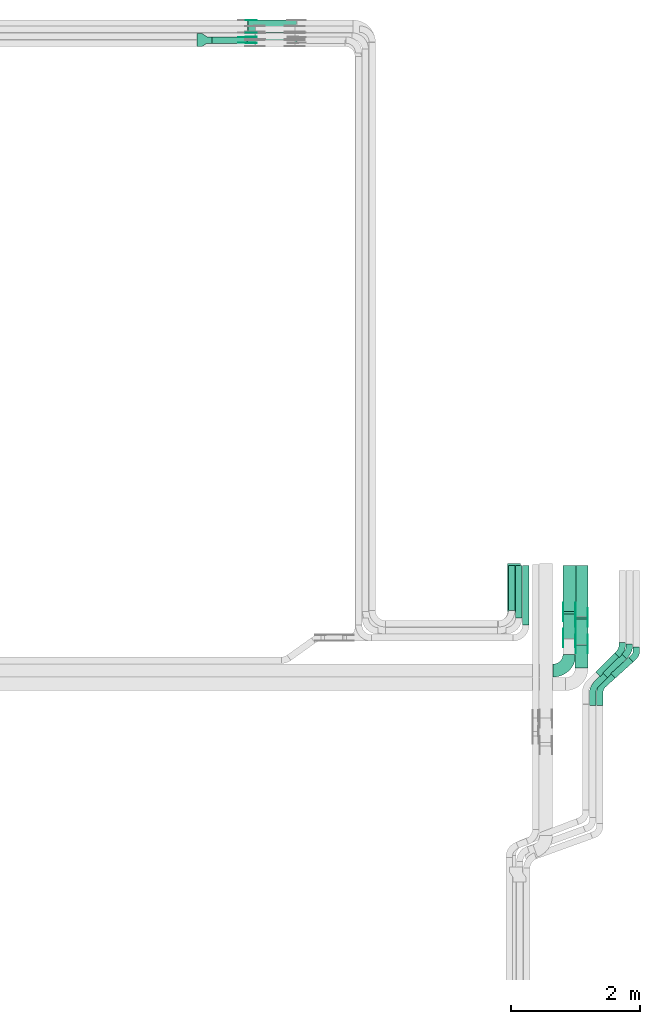
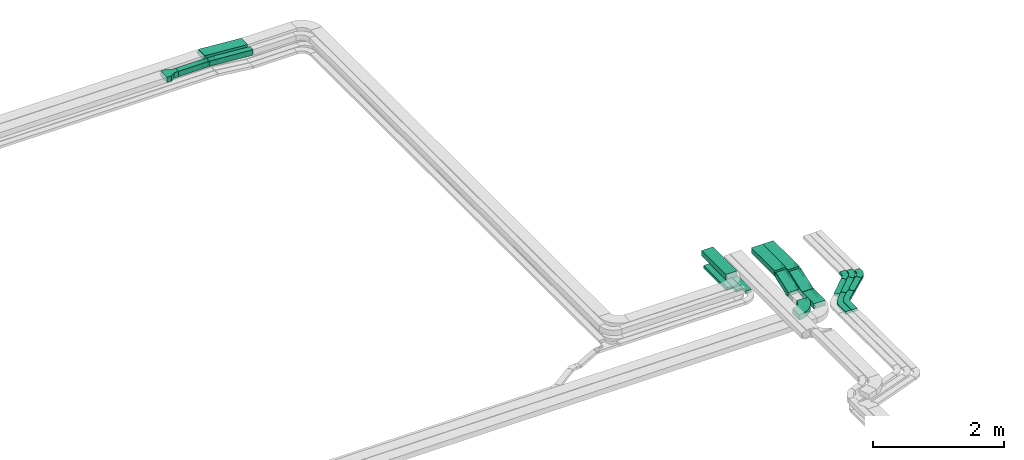
# One storey, part 21 of 23: 29 flow fittings, 15 flow segments.
"""IFC2X3 building model written with IfcOpenShell, lengths in millimetres."""

from ifc_helpers import new_model, entity, si_unit, converted_unit, derived_unit, direction, frame, frame_2d, origin, origin_2d_with_axis, place, context, subcontext, project, spatial, polyline, circle_curve, parameter, trimmed, segment, composite_curve, rectangle, outline, extrude, source, transform, mapped, material, type_object, type_shapes, element, save


model = new_model("IFC2X3")

# Units and contexts
model_context = context("Model", 3, precision=0.01, world=origin(), true_north=direction((6.12303176911189e-17, 1.0)))
body_context = subcontext(model_context, "Body", "Model", "MODEL_VIEW")
ifc_project = project(units=[si_unit("LENGTHUNIT", "METRE", prefix="MILLI"), si_unit("AREAUNIT", "SQUARE_METRE"), si_unit("VOLUMEUNIT", "CUBIC_METRE"), converted_unit("PLANEANGLEUNIT", "DEGREE", entity("IfcRatioMeasure", 0.0174532925199433), si_unit("PLANEANGLEUNIT", "RADIAN"), dimensions=[0, 0, 0, 0, 0, 0, 0]), si_unit("MASSUNIT", "GRAM", prefix="KILO"), derived_unit("MASSDENSITYUNIT", [(si_unit("MASSUNIT", "GRAM", prefix="KILO"), 1), (si_unit("LENGTHUNIT", "METRE"), -3)]), derived_unit("MOMENTOFINERTIAUNIT", [(si_unit("LENGTHUNIT", "METRE"), 4)]), si_unit("TIMEUNIT", "SECOND"), si_unit("FREQUENCYUNIT", "HERTZ"), si_unit("THERMODYNAMICTEMPERATUREUNIT", "DEGREE_CELSIUS"), derived_unit("THERMALTRANSMITTANCEUNIT", [(si_unit("MASSUNIT", "GRAM", prefix="KILO"), 1), (si_unit("THERMODYNAMICTEMPERATUREUNIT", "KELVIN"), -1), (si_unit("TIMEUNIT", "SECOND"), -3)]), derived_unit("VOLUMETRICFLOWRATEUNIT", [(si_unit("LENGTHUNIT", "METRE"), 3), (si_unit("TIMEUNIT", "SECOND"), -1)]), derived_unit("MASSFLOWRATEUNIT", [(si_unit("MASSUNIT", "GRAM", prefix="KILO"), 1), (si_unit("TIMEUNIT", "SECOND"), -1)]), derived_unit("ROTATIONALFREQUENCYUNIT", [(si_unit("TIMEUNIT", "SECOND"), -1)]), si_unit("ELECTRICCURRENTUNIT", "AMPERE"), si_unit("ELECTRICVOLTAGEUNIT", "VOLT"), si_unit("POWERUNIT", "WATT"), si_unit("FORCEUNIT", "NEWTON", prefix="KILO"), si_unit("ILLUMINANCEUNIT", "LUX"), si_unit("LUMINOUSFLUXUNIT", "LUMEN"), si_unit("LUMINOUSINTENSITYUNIT", "CANDELA"), derived_unit("USERDEFINED", [(si_unit("MASSUNIT", "GRAM", prefix="KILO"), -1), (si_unit("LENGTHUNIT", "METRE"), -2), (si_unit("TIMEUNIT", "SECOND"), 3), (si_unit("LUMINOUSFLUXUNIT", "LUMEN"), 1)]), derived_unit("LINEARVELOCITYUNIT", [(si_unit("LENGTHUNIT", "METRE"), 1), (si_unit("TIMEUNIT", "SECOND"), -1)]), si_unit("PRESSUREUNIT", "PASCAL"), derived_unit("USERDEFINED", [(si_unit("LENGTHUNIT", "METRE"), -2), (si_unit("MASSUNIT", "GRAM", prefix="KILO"), 1), (si_unit("TIMEUNIT", "SECOND"), -2)]), derived_unit("LINEARFORCEUNIT", [(si_unit("MASSUNIT", "GRAM", prefix="KILO"), 1), (si_unit("LENGTHUNIT", "METRE"), 1), (si_unit("TIMEUNIT", "SECOND"), -2), (si_unit("LENGTHUNIT", "METRE"), -1)]), derived_unit("PLANARFORCEUNIT", [(si_unit("MASSUNIT", "GRAM", prefix="KILO"), 1), (si_unit("LENGTHUNIT", "METRE"), 1), (si_unit("TIMEUNIT", "SECOND"), -2), (si_unit("LENGTHUNIT", "METRE"), -2)])], contexts=[model_context])

# Site, building, storey
site_placement = place(None, origin())
site = spatial("IfcSite", under=ifc_project, at=site_placement, CompositionType="ELEMENT")
building_placement = place(site_placement, origin())
building = spatial("IfcBuilding", under=site, at=building_placement, CompositionType="ELEMENT")
storey_placement = place(building_placement, frame((0.0, 0.0, 24000.0)))
storey = spatial("IfcBuildingStorey", under=building, at=storey_placement, CompositionType="ELEMENT", Elevation=24000.0)

# Flow segments
cable_carrier_segment_type = type_object("IfcCableCarrierSegmentType", PredefinedType="CABLETRAYSEGMENT")
flow_segment_1_placement = place(storey_placement, frame((62698.48, 18750.0, 3245.4)))
element("IfcFlowSegment", 1, at=flow_segment_1_placement, inside=storey, type_object=cable_carrier_segment_type, context=body_context, shape_type="SweptSolid", body=[
    extrude(rectangle(XDim=543.471422611655, YDim=99.9999999999989, at=origin_2d_with_axis()), frame((271.74, 50.0, 0.0)), (0.0, 0.0, 1.0), 100.000000000003),
])
flow_segment_2_placement = place(storey_placement, frame((67285.53, 9971.0, 2972.83)))
element("IfcFlowSegment", 2, at=flow_segment_2_placement, inside=storey, type_object=cable_carrier_segment_type, context=body_context, shape_type="SweptSolid", body=[
    extrude(rectangle(XDim=699.000000000004, YDim=99.9999999999946, at=origin_2d_with_axis()), frame((50.0, 349.5, 0.0), z_axis=(0.0, 0.0, 1.0), x_axis=(0.0, 1.0, 0.0)), (0.0, 0.0, 1.0), 49.9999999999973),
])
flow_segment_3_placement = place(storey_placement, frame((67395.53, 9861.0, 2972.83)))
element("IfcFlowSegment", 3, at=flow_segment_3_placement, inside=storey, type_object=cable_carrier_segment_type, context=body_context, shape_type="SweptSolid", body=[
    extrude(rectangle(XDim=809.000000000002, YDim=99.9999999999946, at=origin_2d_with_axis()), frame((50.0, 404.5, 0.0), z_axis=(0.0, 0.0, 1.0), x_axis=(0.0, 1.0, 0.0)), (0.0, 0.0, 1.0), 49.9999999999973),
])
flow_segment_4_placement = place(storey_placement, frame((67505.53, 9751.0, 2972.83)))
element("IfcFlowSegment", 4, at=flow_segment_4_placement, inside=storey, type_object=cable_carrier_segment_type, context=body_context, shape_type="SweptSolid", body=[
    extrude(rectangle(XDim=919.000000000008, YDim=99.9999999999946, at=origin_2d_with_axis()), frame((50.0, 459.5, 0.0), z_axis=(0.0, 0.0, 1.0), x_axis=(0.0, 1.0, 0.0)), (0.0, 0.0, 1.0), 49.9999999999973),
])
flow_segment_5_placement = place(storey_placement, frame((67270.08, 9961.0, 3187.83)))
element("IfcFlowSegment", 5, at=flow_segment_5_placement, inside=storey, type_object=cable_carrier_segment_type, context=body_context, shape_type="SweptSolid", body=[
    extrude(rectangle(XDim=739.518749019633, YDim=200.000000000007, at=origin_2d_with_axis()), frame((100.0, 369.76, 0.0), z_axis=(0.0, 0.0, 1.0), x_axis=(0.0, 1.0, 0.0)), (0.0, 0.0, 1.0), 100.000000000003),
])
flow_segment_6_placement = place(storey_placement, frame((63244.25, 18750.0, 3188.19)))
element("IfcFlowSegment", 6, at=flow_segment_6_placement, inside=storey, type_object=cable_carrier_segment_type, context=body_context, shape_type="SweptSolid", body=[
    extrude(rectangle(XDim=100.0, YDim=99.9999999999989, at=origin_2d_with_axis()), frame((3.74, 50.0, 106.98), z_axis=(0.997198819894241, 0.0, -0.0747964812109102), x_axis=(0.0747964812109102, 0.0, 0.997198819894241)), (0.0, 0.0, 1.0), 763.726295743631),
])
flow_segment_7_placement = place(storey_placement, frame((63247.74, 18910.0, 3188.2)))
element("IfcFlowSegment", 7, at=flow_segment_7_placement, inside=storey, type_object=cable_carrier_segment_type, context=body_context, shape_type="SweptSolid", body=[
    extrude(rectangle(XDim=99.999999999999, YDim=199.999999999998, at=origin_2d_with_axis()), frame((3.77, 100.0, 106.98), z_axis=(0.997154606736378, 0.0, -0.0753836206640402), x_axis=(0.0753836206640402, 0.0, 0.997154606736378)), (0.0, 0.0, 1.0), 757.698950074863),
])
flow_segment_8_placement = place(storey_placement, frame((68871.19, 8927.18, 2977.04)))
element("IfcFlowSegment", 8, at=flow_segment_8_placement, inside=storey, type_object=cable_carrier_segment_type, context=body_context, shape_type="SweptSolid", body=[
    extrude(rectangle(XDim=371.773074672143, YDim=99.9999999999984, at=origin_2d_with_axis()), frame((171.46, 161.71, 0.28), z_axis=(0.00112985461369591, 0.00102060214396783, 0.999998840899236), x_axis=(-0.742072934551903, -0.67031741854538, 0.00152256368811346)), (0.0, 0.0, 1.0), 49.9999999999997),
])
flow_segment_9_placement = place(storey_placement, frame((68746.15, 8935.6, 2976.94)))
element("IfcFlowSegment", 9, at=flow_segment_9_placement, inside=storey, type_object=cable_carrier_segment_type, context=body_context, shape_type="SweptSolid", body=[
    extrude(rectangle(XDim=415.989494553877, YDim=100.00000000001, at=origin_2d_with_axis()), frame((182.43, 182.43, 0.44), z_axis=(0.0015024201617621, 0.00150242016176191, 0.99999774273111), x_axis=(-0.707105185056458, -0.707105185056359, 0.00212474296914661)), (0.0, 0.0, 1.0), 50.0000000000083),
])
flow_segment_10_placement = place(storey_placement, frame((68636.15, 8953.17, 2977.04)))
element("IfcFlowSegment", 10, at=flow_segment_10_placement, inside=storey, type_object=cable_carrier_segment_type, context=body_context, shape_type="SweptSolid", body=[
    extrude(rectangle(XDim=415.990331020414, YDim=100.000000000008, at=origin_2d_with_axis()), frame((182.43, 182.43, 0.45), z_axis=(0.00154514644007861, 0.00154514644007847, 0.999997612519629), x_axis=(-0.707105092983034, -0.70710509298294, 0.00218516705141158)), (0.0, 0.0, 1.0), 50.000000000004),
])
flow_segment_11_placement = place(storey_placement, frame((68319.24, 9085.99, 2805.0)))
element("IfcFlowSegment", 11, at=flow_segment_11_placement, inside=storey, type_object=cable_carrier_segment_type, context=body_context, shape_type="SweptSolid", body=[
    extrude(rectangle(XDim=358.479361109274, YDim=200.000000000007, at=origin_2d_with_axis()), frame((100.0, 179.24, 0.0), z_axis=(0.0, 0.0, 1.0), x_axis=(0.0, 1.0, 0.0)), (0.0, 0.0, 1.0), 100.000000000003),
])
flow_segment_12_placement = place(storey_placement, frame((68128.7, 9960.74, 2956.03)))
element("IfcFlowSegment", 12, at=flow_segment_12_placement, inside=storey, type_object=cable_carrier_segment_type, context=body_context, shape_type="SweptSolid", body=[
    extrude(rectangle(XDim=709.258949212396, YDim=200.000000000007, at=origin_2d_with_axis()), frame((100.0, 354.63, 0.0), z_axis=(0.0, 0.0, 1.0), x_axis=(0.0, 1.0, 0.0)), (0.0, 0.0, 1.0), 100.000000000003),
])
flow_segment_13_placement = place(storey_placement, frame((68319.24, 9880.52, 2956.03)))
element("IfcFlowSegment", 13, at=flow_segment_13_placement, inside=storey, type_object=cable_carrier_segment_type, context=body_context, shape_type="SweptSolid", body=[
    extrude(rectangle(XDim=789.479361109084, YDim=200.000000000007, at=origin_2d_with_axis()), frame((100.0, 394.74, 0.0), z_axis=(0.0, 0.0, 1.0), x_axis=(0.0, 1.0, 0.0)), (0.0, 0.0, 1.0), 100.000000000003),
])
flow_segment_14_placement = place(storey_placement, frame((68128.7, 9537.58, 2811.9)))
element("IfcFlowSegment", 14, at=flow_segment_14_placement, inside=storey, type_object=cable_carrier_segment_type, context=body_context, shape_type="SweptSolid", body=[
    extrude(rectangle(XDim=100.000000000003, YDim=410.773733093381, at=frame_2d((0.0, 0.0), x_axis=(0.0, 1.0))), frame((0.0, 209.91, 118.61), z_axis=(1.0, 0.0, 0.0), x_axis=(0.0, -0.936970044567182, -0.34940969589262)), (0.0, 0.0, 1.0), 200.000000000007),
])
flow_segment_15_placement = place(storey_placement, frame((68319.24, 9447.78, 2811.61)))
element("IfcFlowSegment", 15, at=flow_segment_15_placement, inside=storey, type_object=cable_carrier_segment_type, context=body_context, shape_type="SweptSolid", body=[
    extrude(rectangle(XDim=100.000000000004, YDim=420.598079588431, at=frame_2d((0.0, 0.0), x_axis=(0.0, 1.0))), frame((0.0, 214.72, 118.9), z_axis=(1.0, 0.0, 0.0), x_axis=(0.0, -0.939705127606637, -0.341985779163101)), (0.0, 0.0, 1.0), 200.000000000006),
])

# Flow fittings
ifc_material_1 = material()
cable_carrier_fitting_type_1 = type_object("IfcCableCarrierFittingType", PredefinedType="NOTDEFINED", material=ifc_material_1)
shared_shape_1 = source(origin(), body_context, "Body", "SweptSolid", [
    extrude(outline(polyline([(-115.0, -100.0), (-38.33, -100.0), (38.33, -50.0), (115.0, -50.0), (115.0, 50.0), (38.33, 50.0), (-38.33, 100.0), (-115.0, 100.0), (-115.0, -100.0)])), frame((115.0, 0.0, -50.0)), (0.0, 0.0, 1.0), 100.0),
])
type_shapes(cable_carrier_fitting_type_1, [shared_shape_1])
flow_fitting_1_placement = place(storey_placement, frame((62468.48, 18800.0, 3295.4)))
element("IfcFlowFitting", 16, at=flow_fitting_1_placement, inside=storey, type_object=cable_carrier_fitting_type_1, material=ifc_material_1, Name="470_DKC_S5_adapter", context=body_context, shape_type="MappedRepresentation", body=[
    mapped(shared_shape_1, transform((0.0, 0.0, 0.0), scale=1.0)),
])
cable_carrier_fitting_type_2 = type_object("IfcCableCarrierFittingType", Name="470_DKC_S5_Variable Angle Elbow 0-45:-", PredefinedType="NOTDEFINED", material=ifc_material_1)
shared_shape_2 = source(origin(), body_context, "Body", "SweptSolid", [
    extrude(outline(composite_curve([segment(polyline([(-125.75, -225.25), (-124.75, -225.25)]), True, "CONTINUOUS"), segment(trimmed(circle_curve(frame_2d((-124.75, 124.75), x_axis=(0.0, -1.0)), 350.0), [parameter(0.0)], [parameter(90.0000000000001)], True, "PARAMETER"), True, "CONTINUOUS"), segment(polyline([(225.25, 124.75), (225.25, 125.75)]), True, "CONTINUOUS"), segment(polyline([(225.25, 125.75), (25.25, 125.75)]), True, "CONTINUOUS"), segment(polyline([(25.25, 125.75), (25.25, 124.75)]), True, "CONTINUOUS"), segment(trimmed(circle_curve(frame_2d((-124.75, 124.75), x_axis=(0.0, -1.0)), 150.0), [parameter(0.0)], [parameter(90.0000000000001)], True, "PARAMETER"), False, "CONTINUOUS"), segment(polyline([(-124.75, -25.25), (-125.75, -25.25)]), True, "CONTINUOUS"), segment(polyline([(-125.75, -25.25), (-125.75, -225.25)]), True, "CONTINUOUS")], self_intersect=False)), frame((-125.25, 125.25, -50.0)), (0.0, 0.0, 1.0), 100.0),
])
type_shapes(cable_carrier_fitting_type_2, [shared_shape_2])
flow_fitting_2_placement = place(storey_placement, frame((68228.7, 9044.99, 2855.0)))
element("IfcFlowFitting", 17, at=flow_fitting_2_placement, inside=storey, type_object=cable_carrier_fitting_type_2, material=ifc_material_1, Name="470_DKC_S5_Variable Angle Elbow 0-45:-", ObjectType="470_DKC_S5_Variable Angle Elbow 0-45:-", context=body_context, shape_type="MappedRepresentation", body=[
    mapped(shared_shape_2, transform((0.0, 0.0, 0.0), scale=1.0)),
])
ifc_material_2 = material(Name="G")
cable_carrier_fitting_type_3 = type_object("IfcCableCarrierFittingType", PredefinedType="NOTDEFINED", material=ifc_material_2)
shared_shape_3 = source(origin(), body_context, "Body", "SweptSolid", [
    extrude(outline(composite_curve([segment(trimmed(circle_curve(frame_2d((-41.47, 0.0), x_axis=(1.0, 0.0)), 25.0), [parameter(90.0000000000007)], [parameter(270.0)], True, "PARAMETER"), True, "CONTINUOUS"), segment(polyline([(-41.47, -25.0), (-29.97, -25.0)]), True, "CONTINUOUS"), segment(polyline([(-29.97, -25.0), (-28.1, -38.5)]), True, "CONTINUOUS"), segment(polyline([(-28.1, -38.5), (99.53, -38.5)]), True, "CONTINUOUS"), segment(polyline([(99.53, -38.5), (99.53, 38.5)]), True, "CONTINUOUS"), segment(polyline([(99.53, 38.5), (-28.1, 38.5)]), True, "CONTINUOUS"), segment(polyline([(-28.1, 38.5), (-29.97, 25.0)]), True, "CONTINUOUS"), segment(polyline([(-29.97, 25.0), (-41.47, 25.0)]), True, "CONTINUOUS")], self_intersect=False)), frame((41.47, 0.0, 0.0), z_axis=(0.0, 0.0, -1.0), x_axis=(1.0, 0.0, 0.0)), (0.0, 0.0, -1.0), 2.0),
])
type_shapes(cable_carrier_fitting_type_3, [shared_shape_3])
flow_fitting_3_placement = place(storey_placement, frame((63244.97, 18845.46, 3295.4), z_axis=(0.0, 1.0, 0.0), x_axis=(0.997198819894238, 0.0, -0.0747964812109387)))
element("IfcFlowFitting", 18, at=flow_fitting_3_placement, inside=storey, type_object=cable_carrier_fitting_type_3, material=ifc_material_2, context=body_context, shape_type="MappedRepresentation", body=[
    mapped(shared_shape_3, transform((0.0, 0.0, 0.0), scale=1.0)),
])
cable_carrier_fitting_type_4 = type_object("IfcCableCarrierFittingType", PredefinedType="NOTDEFINED", material=ifc_material_2)
type_shapes(cable_carrier_fitting_type_4, [shared_shape_3])
flow_fitting_4_placement = place(storey_placement, frame((63244.97, 18756.54, 3295.4), z_axis=(0.0, -1.0, 0.0), x_axis=(-1.0, 0.0, 0.0)))
element("IfcFlowFitting", 19, at=flow_fitting_4_placement, inside=storey, type_object=cable_carrier_fitting_type_4, material=ifc_material_2, context=body_context, shape_type="MappedRepresentation", body=[
    mapped(shared_shape_3, transform((0.0, 0.0, 0.0), scale=1.0)),
])
for number, where, z_axis, x_axis in (
    (20, (63248.48, 19105.46, 3295.4), (0.0, 1.0, 0.0), (0.997154606736381, 0.0, -0.075383620663996)),
    (21, (68324.16, 9950.0, 3006.03), (1.0, 0.0, 0.0), (0.0, -0.93697004456712, -0.349409695892785)),
):
    element("IfcFlowFitting", number, at=place(storey_placement, frame(where, z_axis=z_axis, x_axis=x_axis)), inside=storey, type_object=cable_carrier_fitting_type_3, material=ifc_material_2, context=body_context, shape_type="MappedRepresentation", body=[
        mapped(shared_shape_3, transform((0.0, 0.0, 0.0), scale=1.0)),
    ])
flow_fitting_5_placement = place(storey_placement, frame((68135.24, 9950.0, 3006.03), z_axis=(-1.0, 0.0, 0.0), x_axis=(0.0, 1.0, 0.0)))
element("IfcFlowFitting", 22, at=flow_fitting_5_placement, inside=storey, type_object=cable_carrier_fitting_type_4, material=ifc_material_2, context=body_context, shape_type="MappedRepresentation", body=[
    mapped(shared_shape_3, transform((0.0, 0.0, 0.0), scale=1.0)),
])
flow_fitting_6_placement = place(storey_placement, frame((68324.16, 9544.99, 2855.0), z_axis=(1.0, 0.0, 0.0), x_axis=(0.0, 0.93697004456712, 0.349409695892785)))
element("IfcFlowFitting", 23, at=flow_fitting_6_placement, inside=storey, type_object=cable_carrier_fitting_type_3, material=ifc_material_2, context=body_context, shape_type="MappedRepresentation", body=[
    mapped(shared_shape_3, transform((0.0, 0.0, 0.0), scale=1.0)),
])
flow_fitting_7_placement = place(storey_placement, frame((68135.24, 9544.99, 2855.0), z_axis=(-1.0, 0.0, 0.0), x_axis=(0.0, -1.0, 0.0)))
element("IfcFlowFitting", 24, at=flow_fitting_7_placement, inside=storey, type_object=cable_carrier_fitting_type_4, material=ifc_material_2, context=body_context, shape_type="MappedRepresentation", body=[
    mapped(shared_shape_3, transform((0.0, 0.0, 0.0), scale=1.0)),
])
flow_fitting_8_placement = place(storey_placement, frame((68514.7, 9870.0, 3006.03), z_axis=(1.0, 0.0, 0.0), x_axis=(0.0, -0.939705127606558, -0.34198577916332)))
element("IfcFlowFitting", 25, at=flow_fitting_8_placement, inside=storey, type_object=cable_carrier_fitting_type_3, material=ifc_material_2, context=body_context, shape_type="MappedRepresentation", body=[
    mapped(shared_shape_3, transform((0.0, 0.0, 0.0), scale=1.0)),
])
flow_fitting_9_placement = place(storey_placement, frame((68325.78, 9870.0, 3006.03), z_axis=(-1.0, 0.0, 0.0), x_axis=(0.0, 1.0, 0.0)))
element("IfcFlowFitting", 26, at=flow_fitting_9_placement, inside=storey, type_object=cable_carrier_fitting_type_4, material=ifc_material_2, context=body_context, shape_type="MappedRepresentation", body=[
    mapped(shared_shape_3, transform((0.0, 0.0, 0.0), scale=1.0)),
])
flow_fitting_10_placement = place(storey_placement, frame((68514.7, 9454.99, 2855.0), z_axis=(1.0, 0.0, 0.0), x_axis=(0.0, 0.939705127606558, 0.34198577916332)))
element("IfcFlowFitting", 27, at=flow_fitting_10_placement, inside=storey, type_object=cable_carrier_fitting_type_3, material=ifc_material_2, context=body_context, shape_type="MappedRepresentation", body=[
    mapped(shared_shape_3, transform((0.0, 0.0, 0.0), scale=1.0)),
])
flow_fitting_11_placement = place(storey_placement, frame((68325.78, 9454.99, 2855.0), z_axis=(-1.0, 0.0, 0.0), x_axis=(0.0, -1.0, 0.0)))
element("IfcFlowFitting", 28, at=flow_fitting_11_placement, inside=storey, type_object=cable_carrier_fitting_type_4, material=ifc_material_2, context=body_context, shape_type="MappedRepresentation", body=[
    mapped(shared_shape_3, transform((0.0, 0.0, 0.0), scale=1.0)),
])
cable_carrier_fitting_type_5 = type_object("IfcCableCarrierFittingType", PredefinedType="NOTDEFINED", material=ifc_material_2)
shared_shape_4 = source(origin(), body_context, "Body", "SweptSolid", [
    extrude(outline(composite_curve([segment(trimmed(circle_curve(frame_2d((-41.47, 0.0), x_axis=(1.0, 0.0)), 25.0), [parameter(90.0000000000007)], [parameter(270.0)], True, "PARAMETER"), True, "CONTINUOUS"), segment(polyline([(-41.47, -25.0), (-29.97, -25.0)]), True, "CONTINUOUS"), segment(polyline([(-29.97, -25.0), (-28.1, -38.5)]), True, "CONTINUOUS"), segment(polyline([(-28.1, -38.5), (99.53, -38.5)]), True, "CONTINUOUS"), segment(polyline([(99.53, -38.5), (99.53, 38.5)]), True, "CONTINUOUS"), segment(polyline([(99.53, 38.5), (-28.1, 38.5)]), True, "CONTINUOUS"), segment(polyline([(-28.1, 38.5), (-29.97, 25.0)]), True, "CONTINUOUS"), segment(polyline([(-29.97, 25.0), (-41.47, 25.0)]), True, "CONTINUOUS")], self_intersect=False)), frame((41.47, 0.0, 0.0)), (0.0, 0.0, 1.0), 2.0),
])
type_shapes(cable_carrier_fitting_type_5, [shared_shape_4])
flow_fitting_12_placement = place(storey_placement, frame((63244.97, 18754.54, 3295.4), z_axis=(0.0, -1.0, 0.0), x_axis=(0.997198819894238, 0.0, -0.0747964812109387)))
element("IfcFlowFitting", 29, at=flow_fitting_12_placement, inside=storey, type_object=cable_carrier_fitting_type_5, material=ifc_material_2, context=body_context, shape_type="MappedRepresentation", body=[
    mapped(shared_shape_4, transform((0.0, 0.0, 0.0), scale=1.0)),
])
cable_carrier_fitting_type_6 = type_object("IfcCableCarrierFittingType", PredefinedType="NOTDEFINED", material=ifc_material_2)
type_shapes(cable_carrier_fitting_type_6, [shared_shape_4])
flow_fitting_13_placement = place(storey_placement, frame((63244.97, 18843.46, 3295.4), z_axis=(0.0, 1.0, 0.0), x_axis=(-1.0, 0.0, 0.0)))
element("IfcFlowFitting", 30, at=flow_fitting_13_placement, inside=storey, type_object=cable_carrier_fitting_type_6, material=ifc_material_2, context=body_context, shape_type="MappedRepresentation", body=[
    mapped(shared_shape_4, transform((0.0, 0.0, 0.0), scale=1.0)),
])
for number, where, z_axis, x_axis in (
    (31, (63248.48, 18914.54, 3295.4), (0.0, -1.0, 0.0), (0.997154606736381, 0.0, -0.075383620663996)),
    (32, (68133.24, 9950.0, 3006.03), (-1.0, 0.0, 0.0), (0.0, -0.93697004456712, -0.349409695892785)),
):
    element("IfcFlowFitting", number, at=place(storey_placement, frame(where, z_axis=z_axis, x_axis=x_axis)), inside=storey, type_object=cable_carrier_fitting_type_5, material=ifc_material_2, context=body_context, shape_type="MappedRepresentation", body=[
        mapped(shared_shape_4, transform((0.0, 0.0, 0.0), scale=1.0)),
    ])
flow_fitting_14_placement = place(storey_placement, frame((68322.16, 9950.0, 3006.03), z_axis=(1.0, 0.0, 0.0), x_axis=(0.0, 1.0, 0.0)))
element("IfcFlowFitting", 33, at=flow_fitting_14_placement, inside=storey, type_object=cable_carrier_fitting_type_6, material=ifc_material_2, context=body_context, shape_type="MappedRepresentation", body=[
    mapped(shared_shape_4, transform((0.0, 0.0, 0.0), scale=1.0)),
])
flow_fitting_15_placement = place(storey_placement, frame((68133.24, 9544.99, 2855.0), z_axis=(-1.0, 0.0, 0.0), x_axis=(0.0, 0.93697004456712, 0.349409695892785)))
element("IfcFlowFitting", 34, at=flow_fitting_15_placement, inside=storey, type_object=cable_carrier_fitting_type_5, material=ifc_material_2, context=body_context, shape_type="MappedRepresentation", body=[
    mapped(shared_shape_4, transform((0.0, 0.0, 0.0), scale=1.0)),
])
flow_fitting_16_placement = place(storey_placement, frame((68322.16, 9544.99, 2855.0), z_axis=(1.0, 0.0, 0.0), x_axis=(0.0, -1.0, 0.0)))
element("IfcFlowFitting", 35, at=flow_fitting_16_placement, inside=storey, type_object=cable_carrier_fitting_type_6, material=ifc_material_2, context=body_context, shape_type="MappedRepresentation", body=[
    mapped(shared_shape_4, transform((0.0, 0.0, 0.0), scale=1.0)),
])
flow_fitting_17_placement = place(storey_placement, frame((68323.78, 9870.0, 3006.03), z_axis=(-1.0, 0.0, 0.0), x_axis=(0.0, -0.939705127606558, -0.34198577916332)))
element("IfcFlowFitting", 36, at=flow_fitting_17_placement, inside=storey, type_object=cable_carrier_fitting_type_5, material=ifc_material_2, context=body_context, shape_type="MappedRepresentation", body=[
    mapped(shared_shape_4, transform((0.0, 0.0, 0.0), scale=1.0)),
])
flow_fitting_18_placement = place(storey_placement, frame((68512.7, 9870.0, 3006.03), z_axis=(1.0, 0.0, 0.0), x_axis=(0.0, 1.0, 0.0)))
element("IfcFlowFitting", 37, at=flow_fitting_18_placement, inside=storey, type_object=cable_carrier_fitting_type_6, material=ifc_material_2, context=body_context, shape_type="MappedRepresentation", body=[
    mapped(shared_shape_4, transform((0.0, 0.0, 0.0), scale=1.0)),
])
flow_fitting_19_placement = place(storey_placement, frame((68323.78, 9454.99, 2855.0), z_axis=(-1.0, 0.0, 0.0), x_axis=(0.0, 0.939705127606558, 0.34198577916332)))
element("IfcFlowFitting", 38, at=flow_fitting_19_placement, inside=storey, type_object=cable_carrier_fitting_type_5, material=ifc_material_2, context=body_context, shape_type="MappedRepresentation", body=[
    mapped(shared_shape_4, transform((0.0, 0.0, 0.0), scale=1.0)),
])
flow_fitting_20_placement = place(storey_placement, frame((68512.7, 9454.99, 2855.0), z_axis=(1.0, 0.0, 0.0), x_axis=(0.0, -1.0, 0.0)))
element("IfcFlowFitting", 39, at=flow_fitting_20_placement, inside=storey, type_object=cable_carrier_fitting_type_6, material=ifc_material_2, context=body_context, shape_type="MappedRepresentation", body=[
    mapped(shared_shape_4, transform((0.0, 0.0, 0.0), scale=1.0)),
])
cable_carrier_fitting_type_7 = type_object("IfcCableCarrierFittingType", Name="470_DKC_S5_CD 90 external vertical angle:-", PredefinedType="NOTDEFINED", material=ifc_material_1)
shared_shape_5 = source(origin(), body_context, "Body", "SweptSolid", [
    extrude(outline(composite_curve([segment(polyline([(-100.84, -82.96), (-47.55, -82.96)]), True, "CONTINUOUS"), segment(trimmed(circle_curve(frame_2d((-47.55, 107.04), x_axis=(0.0, -1.0)), 189.999999999999), [parameter(0.0)], [parameter(47.9076715108795)], True, "PARAMETER"), True, "CONTINUOUS"), segment(polyline([(93.44, -20.32), (129.16, 19.22)]), True, "CONTINUOUS"), segment(polyline([(129.16, 19.22), (54.95, 86.25)]), True, "CONTINUOUS"), segment(polyline([(54.95, 86.25), (19.23, 46.71)]), True, "CONTINUOUS"), segment(trimmed(circle_curve(frame_2d((-47.55, 107.04), x_axis=(0.0, -1.0)), 89.9999999999988), [parameter(0.0)], [parameter(47.9076715108795)], True, "PARAMETER"), False, "CONTINUOUS"), segment(polyline([(-47.55, 17.04), (-100.84, 17.04)]), True, "CONTINUOUS"), segment(polyline([(-100.84, 17.04), (-100.84, -82.96)]), True, "CONTINUOUS")], self_intersect=False)), frame((-14.64, 32.96, -25.0)), (0.0, 0.0, 1.0), 49.9999999999999),
])
type_shapes(cable_carrier_fitting_type_7, [shared_shape_5])
flow_fitting_21_placement = place(storey_placement, frame((69266.32, 9290.92, 3001.35), z_axis=(0.00369935697622955, 0.00482711190193455, 0.999981506703323), x_axis=(0.742060522147523, 0.670306206371416, -0.00598090044267332)))
element("IfcFlowFitting", 40, at=flow_fitting_21_placement, inside=storey, type_object=cable_carrier_fitting_type_7, material=ifc_material_1, Name="470_DKC_S5_CD 90 external vertical angle:-", ObjectType="470_DKC_S5_CD 90 external vertical angle:-", context=body_context, shape_type="MappedRepresentation", body=[
    mapped(shared_shape_5, transform((0.0, 0.0, 0.0), scale=1.0)),
])
cable_carrier_fitting_type_8 = type_object("IfcCableCarrierFittingType", Name="470_DKC_S5_CS 90 internal vertical angle:-", PredefinedType="NOTDEFINED", material=ifc_material_1)
shared_shape_6 = source(origin(), body_context, "Body", "SweptSolid", [
    extrude(outline(composite_curve([segment(polyline([(-248.25, -115.01), (-44.42, -115.01)]), True, "CONTINUOUS"), segment(trimmed(circle_curve(frame_2d((-44.42, 99.99), x_axis=(0.0, -1.0)), 214.999999999999), [parameter(0.0)], [parameter(47.9076715108795)], True, "PARAMETER"), True, "CONTINUOUS"), segment(polyline([(115.12, -44.13), (251.75, 107.12)]), True, "CONTINUOUS"), segment(polyline([(251.75, 107.12), (177.55, 174.15)]), True, "CONTINUOUS"), segment(polyline([(177.55, 174.15), (40.92, 22.9)]), True, "CONTINUOUS"), segment(trimmed(circle_curve(frame_2d((-44.42, 99.99), x_axis=(0.0, -1.0)), 114.999999999999), [parameter(0.0)], [parameter(47.9076715108795)], True, "PARAMETER"), False, "CONTINUOUS"), segment(polyline([(-44.42, -15.01), (-248.25, -15.01)]), True, "CONTINUOUS"), segment(polyline([(-248.25, -15.01), (-248.25, -115.01)]), True, "CONTINUOUS")], self_intersect=False)), frame((-28.88, 65.01, -25.0)), (0.0, 0.0, 1.0), 49.9999999999999),
])
type_shapes(cable_carrier_fitting_type_8, [shared_shape_6])
flow_fitting_22_placement = place(storey_placement, frame((68699.09, 8778.54, 3004.27), z_axis=(0.0036993569762315, 0.00482711190194246, 0.999981506703323), x_axis=(-0.742060522147543, -0.670306206371395, 0.00598090044268004)))
element("IfcFlowFitting", 41, at=flow_fitting_22_placement, inside=storey, type_object=cable_carrier_fitting_type_8, material=ifc_material_1, Name="470_DKC_S5_CS 90 internal vertical angle:-", ObjectType="470_DKC_S5_CS 90 internal vertical angle:-", context=body_context, shape_type="MappedRepresentation", body=[
    mapped(shared_shape_6, transform((0.0, 0.0, 0.0), scale=1.0)),
])
cable_carrier_fitting_type_9 = type_object("IfcCableCarrierFittingType", Name="470_DKC_S5_CD 90 external vertical angle:-", PredefinedType="NOTDEFINED", material=ifc_material_1)
shared_shape_7 = source(origin(), body_context, "Body", "SweptSolid", [
    extrude(outline(composite_curve([segment(polyline([(-99.91, -84.07), (-64.59, -84.07)]), True, "CONTINUOUS"), segment(trimmed(circle_curve(frame_2d((-64.59, 155.93), x_axis=(0.0, -1.0)), 239.999999999999), [parameter(0.0)], [parameter(45.0)], True, "PARAMETER"), True, "CONTINUOUS"), segment(polyline([(105.12, -13.77), (130.09, 11.2)]), True, "CONTINUOUS"), segment(polyline([(130.09, 11.2), (59.38, 81.91)]), True, "CONTINUOUS"), segment(polyline([(59.38, 81.91), (34.41, 56.94)]), True, "CONTINUOUS"), segment(trimmed(circle_curve(frame_2d((-64.59, 155.93), x_axis=(0.0, -1.0)), 139.999999999999), [parameter(0.0)], [parameter(45.0)], True, "PARAMETER"), False, "CONTINUOUS"), segment(polyline([(-64.59, 15.93), (-99.91, 15.93)]), True, "CONTINUOUS"), segment(polyline([(-99.91, 15.93), (-99.91, -84.07)]), True, "CONTINUOUS")], self_intersect=False)), frame((-14.11, 34.07, -25.0)), (0.0, 0.0, 1.0), 49.9999999999999),
])
type_shapes(cable_carrier_fitting_type_9, [shared_shape_7])
flow_fitting_23_placement = place(storey_placement, frame((69156.32, 9345.77, 3001.23), z_axis=(0.00374580509600536, 0.00494649692987204, 0.999980750370879), x_axis=(0.707093424490552, 0.707093424490525, -0.00614638792187161)))
element("IfcFlowFitting", 42, at=flow_fitting_23_placement, inside=storey, type_object=cable_carrier_fitting_type_9, material=ifc_material_1, Name="470_DKC_S5_CD 90 external vertical angle:-", ObjectType="470_DKC_S5_CD 90 external vertical angle:-", context=body_context, shape_type="MappedRepresentation", body=[
    mapped(shared_shape_7, transform((0.0, 0.0, 0.0), scale=1.0)),
])
cable_carrier_fitting_type_10 = type_object("IfcCableCarrierFittingType", Name="470_DKC_S5_CD 90 external vertical angle:-", PredefinedType="NOTDEFINED", material=ifc_material_1)
type_shapes(cable_carrier_fitting_type_10, [shared_shape_7])
flow_fitting_24_placement = place(storey_placement, frame((69046.32, 9363.33, 3001.32), z_axis=(0.00385232162863413, 0.00508715659795252, 0.999979640020644), x_axis=(0.707092654053937, 0.707092654053918, -0.00632116808394613)))
element("IfcFlowFitting", 43, at=flow_fitting_24_placement, inside=storey, type_object=cable_carrier_fitting_type_10, material=ifc_material_1, Name="470_DKC_S5_CD 90 external vertical angle:-", ObjectType="470_DKC_S5_CD 90 external vertical angle:-", context=body_context, shape_type="MappedRepresentation", body=[
    mapped(shared_shape_7, transform((0.0, 0.0, 0.0), scale=1.0)),
])
cable_carrier_fitting_type_11 = type_object("IfcCableCarrierFittingType", Name="470_DKC_S5_CS 90 internal vertical angle:-", PredefinedType="NOTDEFINED", material=ifc_material_1)
shared_shape_8 = source(origin(), body_context, "Body", "SweptSolid", [
    extrude(outline(composite_curve([segment(polyline([(-246.19, -112.76), (-56.85, -112.76)]), True, "CONTINUOUS"), segment(trimmed(circle_curve(frame_2d((-56.85, 137.24), x_axis=(0.0, -1.0)), 249.999999999999), [parameter(0.0)], [parameter(45.0)], True, "PARAMETER"), True, "CONTINUOUS"), segment(polyline([(119.93, -39.54), (253.81, 94.35)]), True, "CONTINUOUS"), segment(polyline([(253.81, 94.35), (183.1, 165.06)]), True, "CONTINUOUS"), segment(polyline([(183.1, 165.06), (49.22, 31.17)]), True, "CONTINUOUS"), segment(trimmed(circle_curve(frame_2d((-56.85, 137.24), x_axis=(0.0, -1.0)), 149.999999999999), [parameter(0.0)], [parameter(45.0)], True, "PARAMETER"), False, "CONTINUOUS"), segment(polyline([(-56.85, -12.76), (-246.19, -12.76)]), True, "CONTINUOUS"), segment(polyline([(-246.19, -12.76), (-246.19, -112.76)]), True, "CONTINUOUS")], self_intersect=False)), frame((-26.0, 62.76, -25.0)), (0.0, 0.0, 1.0), 49.9999999999999),
])
type_shapes(cable_carrier_fitting_type_11, [shared_shape_8])
flow_fitting_25_placement = place(storey_placement, frame((68589.09, 8778.54, 3004.49), z_axis=(0.0037457883770944, 0.00494651364861597, 0.999980750350805), x_axis=(-0.70709342449057, -0.707093424490507, 0.00614638792187687)))
element("IfcFlowFitting", 44, at=flow_fitting_25_placement, inside=storey, type_object=cable_carrier_fitting_type_11, material=ifc_material_1, Name="470_DKC_S5_CS 90 internal vertical angle:-", ObjectType="470_DKC_S5_CS 90 internal vertical angle:-", context=body_context, shape_type="MappedRepresentation", body=[
    mapped(shared_shape_8, transform((0.0, 0.0, 0.0), scale=1.0)),
])

save(model, "model.ifc")
